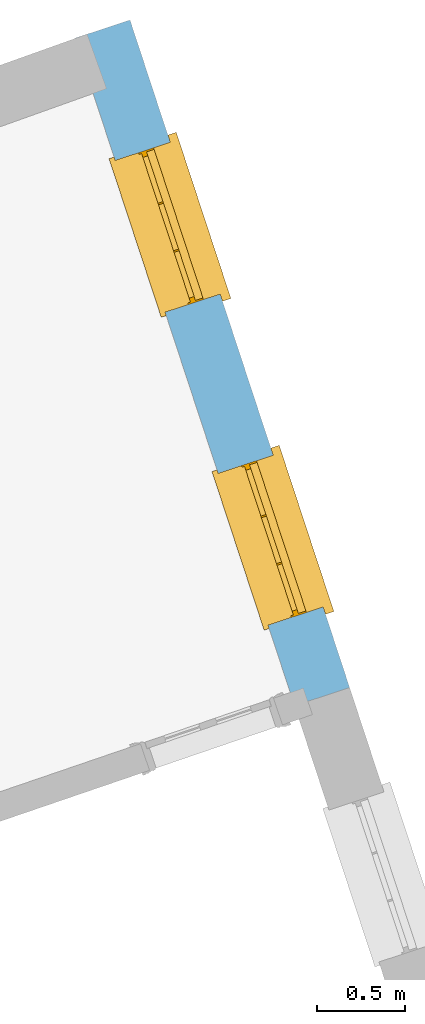
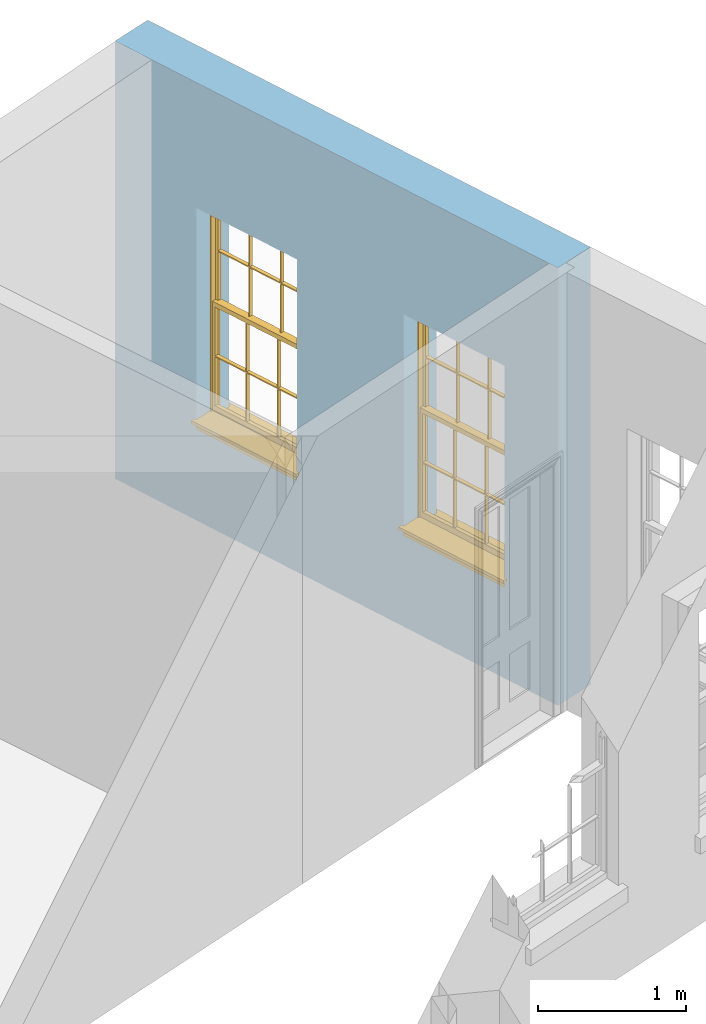
# One storey, part 8 of 10: 2 windows, 2 openings, plus 1 element that does not belong to this part.
"""IFC2X3 building model written with IfcOpenShell, lengths in metres."""

from ifc_helpers import new_model, si_unit, frame, origin, place, context, subcontext, project, spatial, polyline, outline, extrude, faceted_brep, material, layer, layer_set, layer_usage, element, fill, save


model = new_model("IFC2X3")

# Units and contexts
model_context = context("Model", 3, world=origin())
body_context = subcontext(model_context, "Body", "Model", "MODEL_VIEW")
ifc_project = project(units=[si_unit("PLANEANGLEUNIT", "RADIAN"), si_unit("MASSUNIT", "GRAM", prefix="KILO"), si_unit("FORCEUNIT", "NEWTON", prefix="KILO"), si_unit("LENGTHUNIT", "METRE")], contexts=[model_context])

# Site, building, storey
site_placement = place(None, origin())
site = spatial("IfcSite", under=ifc_project, at=site_placement, CompositionType="ELEMENT")
building_placement = place(None, origin())
building = spatial("IfcBuilding", under=site, at=building_placement, Name="Building plot-2", CompositionType="ELEMENT")
storey_placement = place(None, frame((0.0, 0.0, 4.6)))
storey = spatial("IfcBuildingStorey", under=building, at=storey_placement, Name="Floor 1", CompositionType="ELEMENT", Elevation=4.6)

# Wall, openings, windows
ifc_material = material(Name="Masonry")
ifc_layer = layer(ifc_material, 0.33, ventilated=False)
ifc_layer_set = layer_set([ifc_layer], Name="My Wall")
ifc_layer_usage = layer_usage(ifc_layer_set, "AXIS2", "NEGATIVE", 0.08)
wall_placement = place(storey_placement, origin())
wall = element("IfcWallStandardCase", 1, at=wall_placement, inside=storey, material=ifc_layer_usage, Name="exterior", context=body_context, shape_type="SweptSolid", body=[
    extrude(outline(polyline([(36.0387683534412, 35.8899636257678), (36.3522408394225, 35.9930897647079), (35.1023589867895, 39.7923551648735), (34.7888865008082, 39.6892290259334), (36.0387683534412, 35.8899636257678)])), origin(), (0.0, 0.0, 1.0), 3.6),
])
opening_1_placement = place(storey_placement, frame((0.0, 0.0, 0.75)))
opening_1 = element("IfcOpeningElement", 2, at=opening_1_placement, cuts=wall, Name="Opening", ObjectType="Opening", context=body_context, shape_type="SweptSolid", body=[
    extrude(outline(polyline([(36.2014909123295, 36.4513242617331), (35.9171127716158, 37.3157483897422), (35.6036402856345, 37.2126222508021), (35.8880184263481, 36.348198122793), (36.2014909123295, 36.4513242617331)])), origin(), (0.0, 0.0, 1.0), 1.82),
])
opening_2_placement = place(storey_placement, frame((0.0, 0.0, 0.75)))
opening_2 = element("IfcOpeningElement", 3, at=opening_2_placement, cuts=wall, Name="Opening", ObjectType="Opening", context=body_context, shape_type="SweptSolid", body=[
    extrude(outline(polyline([(35.6156129174297, 38.2322173837927), (35.331234776716, 39.0966415118018), (35.0177622907347, 38.9935153728617), (35.3021404314483, 38.1290912448526), (35.6156129174297, 38.2322173837927)])), origin(), (0.0, 0.0, 1.0), 1.82),
])
window_1_placement = place(storey_placement, frame((35.964011756283, 36.3731983988997, 0.75), z_axis=(0.0, 0.0, 1.0), x_axis=(-0.284378140713621, 0.864424128009084, 0.0)))
window_1 = element("IfcWindow", 4, at=window_1_placement, inside=storey, Name="toilet outside window", OverallHeight=1.82, OverallWidth=0.91, context=body_context, shape_type="Brep", held_by="IfcProductRepresentation", body=[
    faceted_brep([(0.033125, -0.105, 0.975209), (0.01, -0.105, 0.975209), (0.033125, -0.105, 1.376042), (0.876875, -0.105, 0.975209), (0.876875, -0.105, 1.376042), (0.9, -0.105, 0.975209), (0.876875, -0.105, 1.386042), (0.876875, -0.105, 1.786875), (0.9, -0.105, 1.81), (0.033125, -0.105, 1.786875), (0.033125, -0.105, 1.386042), (0.01, -0.105, 1.81), (0.876875, -0.135, 1.376042), (0.876875, -0.135, 0.975209), (0.9, -0.135, 0.937083), (0.033125, -0.135, 1.786875), (0.01, -0.135, 1.81), (0.033125, -0.135, 1.386042), (0.01, -0.135, 0.937083), (0.033125, -0.135, 0.975209), (0.033125, -0.135, 1.376042), (0.876875, -0.135, 1.786875), (0.876875, -0.135, 1.386042), (0.9, -0.135, 1.81), (0.033125, -0.105, 0.937083), (0.01, -0.105, 0.937083), (0.033125, -0.105, 0.53625), (0.876875, -0.105, 0.937083), (0.876875, -0.105, 0.53625), (0.9, -0.105, 0.937083), (0.876875, -0.105, 0.52625), (0.876875, -0.105, 0.125417), (0.9, -0.105, 0.077167), (0.033125, -0.105, 0.125417), (0.033125, -0.105, 0.52625), (0.01, -0.105, 0.077167), (-0.0425, -0.25, 0.01), (-0.0425, -0.3, 0.001667), (0.0, -0.25, 0.01), (0.9525, -0.25, 0.01), (0.91, -0.25, 0.01), (0.9525, -0.3, 0.001667), (-0.02, 0.08, 0.077167), (0.0, 0.08, 0.077167), (-0.02, 0.11, 0.077167), (0.0, -0.06, 0.077167), (0.01, -0.06, 0.077167), (0.91, -0.06, 0.077167), (0.91, 0.08, 0.077167), (0.9, -0.06, 0.077167), (0.93, 0.08, 0.077167), (0.93, 0.11, 0.077167), (0.01, -0.075, 0.975209), (0.9, -0.075, 0.975209), (0.876875, -0.075, 0.125417), (0.876875, -0.075, 0.52625), (0.9, -0.075, 0.077167), (0.876875, -0.075, 0.53625), (0.876875, -0.075, 0.937083), (0.033125, -0.075, 0.125417), (0.01, -0.075, 0.077167), (0.033125, -0.075, 0.52625), (0.033125, -0.075, 0.937083), (0.033125, -0.075, 0.53625), (-0.02, 0.08, 0.052167), (-0.02, 0.11, 0.052167), (0.93, 0.11, 0.052167), (0.93, 0.08, 0.052167), (0.91, 0.08, 0.052167), (0.0, 0.08, 0.052167), (0.91, -0.15, 0.026667), (0.0, -0.15, 0.026667), (-0.0425, -0.3, -0.123333), (0.9525, -0.3, -0.123333), (-0.0425, -0.25, -0.123333), (0.9525, -0.25, -0.123333), (0.01, -0.06, 1.81), (0.9, -0.06, 1.81), (0.0, -0.06, 1.82), (0.91, -0.06, 1.82), (0.01, -0.15, 0.077167), (0.9, -0.15, 0.077167), (0.592292, -0.105, 0.125417), (0.592292, -0.075, 0.125417), (0.317708, -0.075, 0.125417), (0.317708, -0.105, 0.125417), (0.592292, -0.105, 0.53625), (0.317708, -0.105, 0.53625), (0.317708, -0.105, 0.52625), (0.592292, -0.105, 0.52625), (0.592292, -0.075, 0.53625), (0.317708, -0.075, 0.53625), (0.592292, -0.135, 1.386042), (0.592292, -0.105, 1.386042), (0.317708, -0.105, 1.386042), (0.317708, -0.135, 1.386042), (0.317708, -0.135, 1.376042), (0.592292, -0.135, 1.376042), (0.317708, -0.105, 1.376042), (0.592292, -0.105, 1.376042), (0.602292, -0.135, 1.376042), (0.592292, -0.135, 0.975209), (0.602292, -0.135, 0.975209), (0.602292, -0.105, 0.975209), (0.592292, -0.105, 0.975209), (0.602292, -0.105, 1.376042), (0.602292, -0.075, 0.53625), (0.602292, -0.105, 0.53625), (0.317708, -0.075, 0.52625), (0.307708, -0.075, 0.125417), (0.307708, -0.075, 0.52625), (0.602292, -0.075, 0.52625), (0.602292, -0.075, 0.125417), (0.592292, -0.075, 0.52625), (0.307708, -0.075, 0.53625), (0.317708, -0.075, 0.937083), (0.307708, -0.075, 0.937083), (0.602292, -0.075, 0.937083), (0.592292, -0.075, 0.937083), (0.307708, -0.105, 0.52625), (0.307708, -0.105, 0.125417), (0.307708, -0.105, 0.53625), (0.307708, -0.105, 0.937083), (0.592292, -0.105, 0.937083), (0.317708, -0.105, 0.937083), (0.602292, -0.105, 0.937083), (0.602292, -0.105, 0.52625), (0.602292, -0.105, 0.125417), (0.307708, -0.135, 1.386042), (0.307708, -0.135, 1.376042), (0.307708, -0.135, 0.975209), (0.317708, -0.135, 0.975209), (0.317708, -0.135, 1.786875), (0.307708, -0.135, 1.786875), (0.602292, -0.135, 1.786875), (0.592292, -0.135, 1.786875), (0.602292, -0.135, 1.386042), (0.602292, -0.105, 1.386042), (0.307708, -0.105, 1.386042), (0.307708, -0.105, 1.786875), (0.317708, -0.105, 1.786875), (0.592292, -0.105, 1.786875), (0.602292, -0.105, 1.786875), (0.307708, -0.105, 1.376042), (0.317708, -0.105, 0.975209), (0.307708, -0.105, 0.975209), (0.91, -0.15, 1.82), (0.9, -0.15, 1.81), (0.01, -0.15, 1.81), (0.0, -0.15, 1.82), (0.91, -0.25, 0.0), (0.0, -0.25, 0.0), (0.91, 0.08, 0.0), (0.0, 0.08, 0.0)], [[[0, 1, 2]], [[3, 4, 5]], [[6, 7, 8]], [[9, 10, 11]], [[12, 13, 14]], [[15, 16, 17]], [[18, 19, 20]], [[21, 22, 23]], [[24, 25, 26]], [[27, 28, 29]], [[30, 31, 32]], [[33, 34, 35]], [[14, 27, 29]], [[25, 24, 18]], [[36, 37, 38]], [[39, 40, 41]], [[42, 43, 44]], [[45, 46, 43]], [[47, 48, 49]], [[50, 51, 48]], [[1, 0, 52]], [[5, 53, 3]], [[54, 55, 56]], [[57, 58, 53]], [[59, 60, 61]], [[62, 63, 52]], [[48, 43, 46, 49]], [[51, 44, 43, 48]], [[64, 42, 44, 65]], [[65, 44, 51, 66]], [[66, 51, 50, 67]], [[65, 66, 68, 69]], [[60, 56, 49, 46]], [[70, 71, 38, 40]], [[37, 41, 40, 38]], [[37, 72, 73, 41]], [[74, 75, 73, 72]], [[8, 11, 76, 77]], [[76, 78, 79, 77]], [[32, 35, 80, 81]], [[81, 80, 71, 70]], [[82, 83, 84, 85]], [[86, 87, 88, 89]], [[86, 90, 91, 87]], [[92, 93, 94, 95]], [[92, 95, 96, 97]], [[96, 98, 99, 97]], [[100, 97, 101, 102]], [[103, 104, 99, 105]], [[97, 99, 104, 101]], [[102, 103, 105, 100]], [[28, 57, 106, 107]], [[108, 84, 109, 110]], [[111, 112, 83, 113]], [[114, 110, 61, 63]], [[90, 113, 108, 91]], [[115, 91, 114, 116]], [[117, 106, 90, 118]], [[111, 106, 57, 55]], [[119, 110, 109, 120]], [[34, 61, 110, 119]], [[89, 113, 83, 82]], [[88, 108, 113, 89]], [[85, 84, 108, 88]], [[121, 114, 63, 26]], [[122, 116, 114, 121]], [[123, 118, 90, 86]], [[87, 91, 115, 124]], [[107, 106, 117, 125]], [[126, 111, 55, 30]], [[127, 112, 111, 126]], [[126, 30, 28, 107]], [[88, 119, 120, 85]], [[126, 89, 82, 127]], [[125, 123, 86, 107]], [[121, 26, 34, 119]], [[124, 122, 121, 87]], [[128, 17, 20, 129]], [[96, 129, 130, 131]], [[132, 133, 128, 95]], [[134, 135, 92, 136]], [[100, 12, 22, 136]], [[137, 6, 4, 105]], [[94, 138, 139, 140]], [[137, 93, 141, 142]], [[99, 98, 94, 93]], [[143, 2, 10, 138]], [[144, 145, 143, 98]], [[129, 143, 145, 130]], [[20, 2, 143, 129]], [[131, 144, 98, 96]], [[128, 138, 10, 17]], [[133, 139, 138, 128]], [[135, 141, 93, 92]], [[95, 94, 140, 132]], [[22, 6, 137, 136]], [[136, 137, 142, 134]], [[100, 105, 4, 12]], [[107, 86, 89, 126]], [[106, 111, 113, 90]], [[91, 108, 110, 114]], [[87, 121, 119, 88]], [[97, 100, 136, 92]], [[129, 96, 95, 128]], [[98, 143, 138, 94]], [[105, 99, 93, 137]], [[131, 101, 104, 144]], [[124, 115, 118, 123]], [[132, 140, 141, 135]], [[120, 109, 59, 33]], [[15, 9, 139, 133]], [[134, 142, 7, 21]], [[31, 54, 112, 127]], [[36, 74, 72, 37]], [[39, 41, 73, 75]], [[18, 14, 101, 131]], [[23, 16, 132, 135]], [[83, 56, 60, 84]], [[52, 53, 118, 115]], [[53, 52, 144, 104]], [[11, 8, 141, 140]], [[14, 18, 124, 123]], [[2, 1, 11, 10]], [[8, 5, 4, 6]], [[57, 53, 56, 55]], [[60, 52, 63, 61]], [[26, 25, 35, 34]], [[32, 29, 28, 30]], [[14, 23, 22, 12]], [[18, 20, 17, 16]], [[19, 0, 2, 20]], [[17, 10, 9, 15]], [[12, 4, 3, 13]], [[21, 7, 6, 22]], [[27, 58, 57, 28]], [[30, 55, 54, 31]], [[33, 59, 61, 34]], [[26, 63, 62, 24]], [[5, 8, 77, 53]], [[76, 11, 1, 52]], [[46, 45, 78, 76]], [[49, 77, 79, 47]], [[70, 146, 147, 81]], [[71, 80, 148, 149]], [[19, 130, 145, 0]], [[102, 13, 3, 103]], [[116, 122, 24, 62]], [[29, 32, 81, 14]], [[80, 35, 25, 18]], [[60, 46, 76, 52]], [[77, 49, 56, 53]], [[23, 14, 81, 147]], [[16, 148, 80, 18]], [[35, 85, 120]], [[120, 33, 35]], [[127, 82, 32]], [[32, 31, 127]], [[32, 82, 85, 35]], [[102, 101, 14]], [[14, 13, 102]], [[18, 131, 130]], [[130, 19, 18]], [[134, 21, 23]], [[23, 135, 134]], [[16, 15, 133]], [[133, 132, 16]], [[11, 140, 139]], [[139, 9, 11]], [[142, 141, 8]], [[8, 7, 142]], [[23, 147, 148, 16]], [[146, 149, 148, 147]], [[52, 115, 116]], [[116, 62, 52]], [[118, 53, 117]], [[58, 117, 53]], [[27, 125, 117, 58]], [[56, 83, 112]], [[112, 54, 56]], [[109, 84, 60]], [[60, 59, 109]], [[125, 27, 14]], [[14, 123, 125]], [[122, 124, 18]], [[18, 24, 122]], [[145, 144, 52]], [[52, 0, 145]], [[103, 3, 53]], [[53, 104, 103]], [[79, 78, 149, 146]], [[78, 45, 71, 149]], [[146, 70, 47, 79]], [[150, 75, 74, 151]], [[68, 66, 67]], [[48, 68, 67, 50]], [[69, 64, 65]], [[42, 64, 69, 43]], [[69, 68, 152, 153]], [[70, 68, 48, 47]], [[150, 152, 68, 70]], [[43, 69, 71, 45]], [[69, 153, 151, 71]], [[152, 150, 151, 153]], [[38, 151, 74, 36]], [[71, 151, 38]], [[39, 75, 150, 40]], [[40, 150, 70]]]),
])
fill(opening_1, window_1)
window_2_placement = place(storey_placement, frame((35.3781337613832, 38.1540915209593, 0.75), z_axis=(0.0, 0.0, 1.0), x_axis=(-0.284378140713621, 0.864424128009084, 0.0)))
window_2 = element("IfcWindow", 5, at=window_2_placement, inside=storey, Name="toilet outside window", OverallHeight=1.82, OverallWidth=0.91, context=body_context, shape_type="Brep", held_by="IfcProductRepresentation", body=[
    faceted_brep([(0.033125, -0.105, 0.975209), (0.01, -0.105, 0.975209), (0.033125, -0.105, 1.376042), (0.876875, -0.105, 0.975209), (0.876875, -0.105, 1.376042), (0.9, -0.105, 0.975209), (0.876875, -0.105, 1.386042), (0.876875, -0.105, 1.786875), (0.9, -0.105, 1.81), (0.033125, -0.105, 1.786875), (0.033125, -0.105, 1.386042), (0.01, -0.105, 1.81), (0.876875, -0.135, 1.376042), (0.876875, -0.135, 0.975209), (0.9, -0.135, 0.937083), (0.033125, -0.135, 1.786875), (0.01, -0.135, 1.81), (0.033125, -0.135, 1.386042), (0.01, -0.135, 0.937083), (0.033125, -0.135, 0.975209), (0.033125, -0.135, 1.376042), (0.876875, -0.135, 1.786875), (0.876875, -0.135, 1.386042), (0.9, -0.135, 1.81), (0.033125, -0.105, 0.937083), (0.01, -0.105, 0.937083), (0.033125, -0.105, 0.53625), (0.876875, -0.105, 0.937083), (0.876875, -0.105, 0.53625), (0.9, -0.105, 0.937083), (0.876875, -0.105, 0.52625), (0.876875, -0.105, 0.125417), (0.9, -0.105, 0.077167), (0.033125, -0.105, 0.125417), (0.033125, -0.105, 0.52625), (0.01, -0.105, 0.077167), (-0.0425, -0.25, 0.01), (-0.0425, -0.3, 0.001667), (0.0, -0.25, 0.01), (0.9525, -0.25, 0.01), (0.91, -0.25, 0.01), (0.9525, -0.3, 0.001667), (-0.02, 0.08, 0.077167), (0.0, 0.08, 0.077167), (-0.02, 0.11, 0.077167), (0.0, -0.06, 0.077167), (0.01, -0.06, 0.077167), (0.91, -0.06, 0.077167), (0.91, 0.08, 0.077167), (0.9, -0.06, 0.077167), (0.93, 0.08, 0.077167), (0.93, 0.11, 0.077167), (0.01, -0.075, 0.975209), (0.9, -0.075, 0.975209), (0.876875, -0.075, 0.125417), (0.876875, -0.075, 0.52625), (0.9, -0.075, 0.077167), (0.876875, -0.075, 0.53625), (0.876875, -0.075, 0.937083), (0.033125, -0.075, 0.125417), (0.01, -0.075, 0.077167), (0.033125, -0.075, 0.52625), (0.033125, -0.075, 0.937083), (0.033125, -0.075, 0.53625), (-0.02, 0.08, 0.052167), (-0.02, 0.11, 0.052167), (0.93, 0.11, 0.052167), (0.93, 0.08, 0.052167), (0.91, 0.08, 0.052167), (0.0, 0.08, 0.052167), (0.91, -0.15, 0.026667), (0.0, -0.15, 0.026667), (-0.0425, -0.3, -0.123333), (0.9525, -0.3, -0.123333), (-0.0425, -0.25, -0.123333), (0.9525, -0.25, -0.123333), (0.01, -0.06, 1.81), (0.9, -0.06, 1.81), (0.0, -0.06, 1.82), (0.91, -0.06, 1.82), (0.01, -0.15, 0.077167), (0.9, -0.15, 0.077167), (0.592292, -0.105, 0.125417), (0.592292, -0.075, 0.125417), (0.317708, -0.075, 0.125417), (0.317708, -0.105, 0.125417), (0.592292, -0.105, 0.53625), (0.317708, -0.105, 0.53625), (0.317708, -0.105, 0.52625), (0.592292, -0.105, 0.52625), (0.592292, -0.075, 0.53625), (0.317708, -0.075, 0.53625), (0.592292, -0.135, 1.386042), (0.592292, -0.105, 1.386042), (0.317708, -0.105, 1.386042), (0.317708, -0.135, 1.386042), (0.317708, -0.135, 1.376042), (0.592292, -0.135, 1.376042), (0.317708, -0.105, 1.376042), (0.592292, -0.105, 1.376042), (0.602292, -0.135, 1.376042), (0.592292, -0.135, 0.975209), (0.602292, -0.135, 0.975209), (0.602292, -0.105, 0.975209), (0.592292, -0.105, 0.975209), (0.602292, -0.105, 1.376042), (0.602292, -0.075, 0.53625), (0.602292, -0.105, 0.53625), (0.317708, -0.075, 0.52625), (0.307708, -0.075, 0.125417), (0.307708, -0.075, 0.52625), (0.602292, -0.075, 0.52625), (0.602292, -0.075, 0.125417), (0.592292, -0.075, 0.52625), (0.307708, -0.075, 0.53625), (0.317708, -0.075, 0.937083), (0.307708, -0.075, 0.937083), (0.602292, -0.075, 0.937083), (0.592292, -0.075, 0.937083), (0.307708, -0.105, 0.52625), (0.307708, -0.105, 0.125417), (0.307708, -0.105, 0.53625), (0.307708, -0.105, 0.937083), (0.592292, -0.105, 0.937083), (0.317708, -0.105, 0.937083), (0.602292, -0.105, 0.937083), (0.602292, -0.105, 0.52625), (0.602292, -0.105, 0.125417), (0.307708, -0.135, 1.386042), (0.307708, -0.135, 1.376042), (0.307708, -0.135, 0.975209), (0.317708, -0.135, 0.975209), (0.317708, -0.135, 1.786875), (0.307708, -0.135, 1.786875), (0.602292, -0.135, 1.786875), (0.592292, -0.135, 1.786875), (0.602292, -0.135, 1.386042), (0.602292, -0.105, 1.386042), (0.307708, -0.105, 1.386042), (0.307708, -0.105, 1.786875), (0.317708, -0.105, 1.786875), (0.592292, -0.105, 1.786875), (0.602292, -0.105, 1.786875), (0.307708, -0.105, 1.376042), (0.317708, -0.105, 0.975209), (0.307708, -0.105, 0.975209), (0.91, -0.15, 1.82), (0.9, -0.15, 1.81), (0.01, -0.15, 1.81), (0.0, -0.15, 1.82), (0.91, -0.25, 0.0), (0.0, -0.25, 0.0), (0.91, 0.08, 0.0), (0.0, 0.08, 0.0)], [[[0, 1, 2]], [[3, 4, 5]], [[6, 7, 8]], [[9, 10, 11]], [[12, 13, 14]], [[15, 16, 17]], [[18, 19, 20]], [[21, 22, 23]], [[24, 25, 26]], [[27, 28, 29]], [[30, 31, 32]], [[33, 34, 35]], [[14, 27, 29]], [[25, 24, 18]], [[36, 37, 38]], [[39, 40, 41]], [[42, 43, 44]], [[45, 46, 43]], [[47, 48, 49]], [[50, 51, 48]], [[1, 0, 52]], [[5, 53, 3]], [[54, 55, 56]], [[57, 58, 53]], [[59, 60, 61]], [[62, 63, 52]], [[48, 43, 46, 49]], [[51, 44, 43, 48]], [[64, 42, 44, 65]], [[65, 44, 51, 66]], [[66, 51, 50, 67]], [[65, 66, 68, 69]], [[60, 56, 49, 46]], [[70, 71, 38, 40]], [[37, 41, 40, 38]], [[37, 72, 73, 41]], [[74, 75, 73, 72]], [[8, 11, 76, 77]], [[76, 78, 79, 77]], [[32, 35, 80, 81]], [[81, 80, 71, 70]], [[82, 83, 84, 85]], [[86, 87, 88, 89]], [[86, 90, 91, 87]], [[92, 93, 94, 95]], [[92, 95, 96, 97]], [[96, 98, 99, 97]], [[100, 97, 101, 102]], [[103, 104, 99, 105]], [[97, 99, 104, 101]], [[102, 103, 105, 100]], [[28, 57, 106, 107]], [[108, 84, 109, 110]], [[111, 112, 83, 113]], [[114, 110, 61, 63]], [[90, 113, 108, 91]], [[115, 91, 114, 116]], [[117, 106, 90, 118]], [[111, 106, 57, 55]], [[119, 110, 109, 120]], [[34, 61, 110, 119]], [[89, 113, 83, 82]], [[88, 108, 113, 89]], [[85, 84, 108, 88]], [[121, 114, 63, 26]], [[122, 116, 114, 121]], [[123, 118, 90, 86]], [[87, 91, 115, 124]], [[107, 106, 117, 125]], [[126, 111, 55, 30]], [[127, 112, 111, 126]], [[126, 30, 28, 107]], [[88, 119, 120, 85]], [[126, 89, 82, 127]], [[125, 123, 86, 107]], [[121, 26, 34, 119]], [[124, 122, 121, 87]], [[128, 17, 20, 129]], [[96, 129, 130, 131]], [[132, 133, 128, 95]], [[134, 135, 92, 136]], [[100, 12, 22, 136]], [[137, 6, 4, 105]], [[94, 138, 139, 140]], [[137, 93, 141, 142]], [[99, 98, 94, 93]], [[143, 2, 10, 138]], [[144, 145, 143, 98]], [[129, 143, 145, 130]], [[20, 2, 143, 129]], [[131, 144, 98, 96]], [[128, 138, 10, 17]], [[133, 139, 138, 128]], [[135, 141, 93, 92]], [[95, 94, 140, 132]], [[22, 6, 137, 136]], [[136, 137, 142, 134]], [[100, 105, 4, 12]], [[107, 86, 89, 126]], [[106, 111, 113, 90]], [[91, 108, 110, 114]], [[87, 121, 119, 88]], [[97, 100, 136, 92]], [[129, 96, 95, 128]], [[98, 143, 138, 94]], [[105, 99, 93, 137]], [[131, 101, 104, 144]], [[124, 115, 118, 123]], [[132, 140, 141, 135]], [[120, 109, 59, 33]], [[15, 9, 139, 133]], [[134, 142, 7, 21]], [[31, 54, 112, 127]], [[36, 74, 72, 37]], [[39, 41, 73, 75]], [[18, 14, 101, 131]], [[23, 16, 132, 135]], [[83, 56, 60, 84]], [[52, 53, 118, 115]], [[53, 52, 144, 104]], [[11, 8, 141, 140]], [[14, 18, 124, 123]], [[2, 1, 11, 10]], [[8, 5, 4, 6]], [[57, 53, 56, 55]], [[60, 52, 63, 61]], [[26, 25, 35, 34]], [[32, 29, 28, 30]], [[14, 23, 22, 12]], [[18, 20, 17, 16]], [[19, 0, 2, 20]], [[17, 10, 9, 15]], [[12, 4, 3, 13]], [[21, 7, 6, 22]], [[27, 58, 57, 28]], [[30, 55, 54, 31]], [[33, 59, 61, 34]], [[26, 63, 62, 24]], [[5, 8, 77, 53]], [[76, 11, 1, 52]], [[46, 45, 78, 76]], [[49, 77, 79, 47]], [[70, 146, 147, 81]], [[71, 80, 148, 149]], [[19, 130, 145, 0]], [[102, 13, 3, 103]], [[116, 122, 24, 62]], [[29, 32, 81, 14]], [[80, 35, 25, 18]], [[60, 46, 76, 52]], [[77, 49, 56, 53]], [[23, 14, 81, 147]], [[16, 148, 80, 18]], [[35, 85, 120]], [[120, 33, 35]], [[127, 82, 32]], [[32, 31, 127]], [[32, 82, 85, 35]], [[102, 101, 14]], [[14, 13, 102]], [[18, 131, 130]], [[130, 19, 18]], [[134, 21, 23]], [[23, 135, 134]], [[16, 15, 133]], [[133, 132, 16]], [[11, 140, 139]], [[139, 9, 11]], [[142, 141, 8]], [[8, 7, 142]], [[23, 147, 148, 16]], [[146, 149, 148, 147]], [[52, 115, 116]], [[116, 62, 52]], [[118, 53, 117]], [[58, 117, 53]], [[27, 125, 117, 58]], [[56, 83, 112]], [[112, 54, 56]], [[109, 84, 60]], [[60, 59, 109]], [[125, 27, 14]], [[14, 123, 125]], [[122, 124, 18]], [[18, 24, 122]], [[145, 144, 52]], [[52, 0, 145]], [[103, 3, 53]], [[53, 104, 103]], [[79, 78, 149, 146]], [[78, 45, 71, 149]], [[146, 70, 47, 79]], [[150, 75, 74, 151]], [[68, 66, 67]], [[48, 68, 67, 50]], [[69, 64, 65]], [[42, 64, 69, 43]], [[69, 68, 152, 153]], [[70, 68, 48, 47]], [[150, 152, 68, 70]], [[43, 69, 71, 45]], [[69, 153, 151, 71]], [[152, 150, 151, 153]], [[38, 151, 74, 36]], [[71, 151, 38]], [[39, 75, 150, 40]], [[40, 150, 70]]]),
])
fill(opening_2, window_2)

save(model, "model.ifc")
